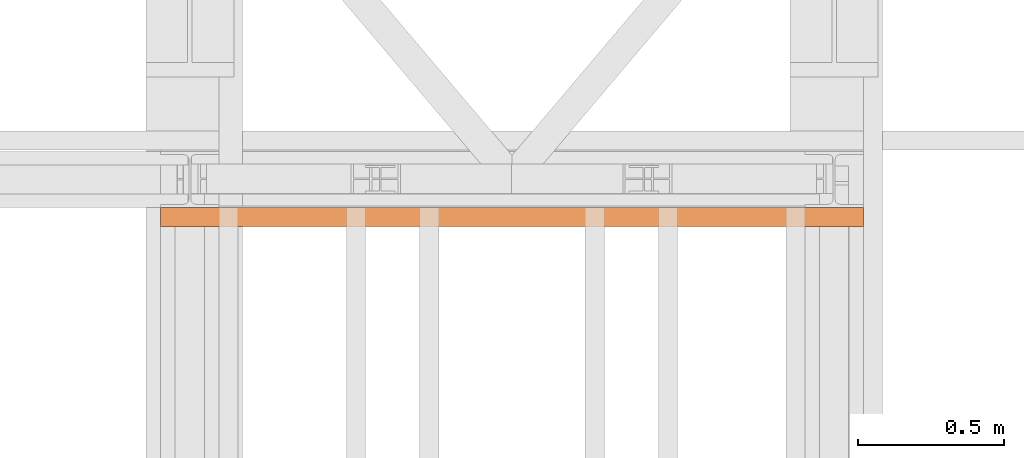
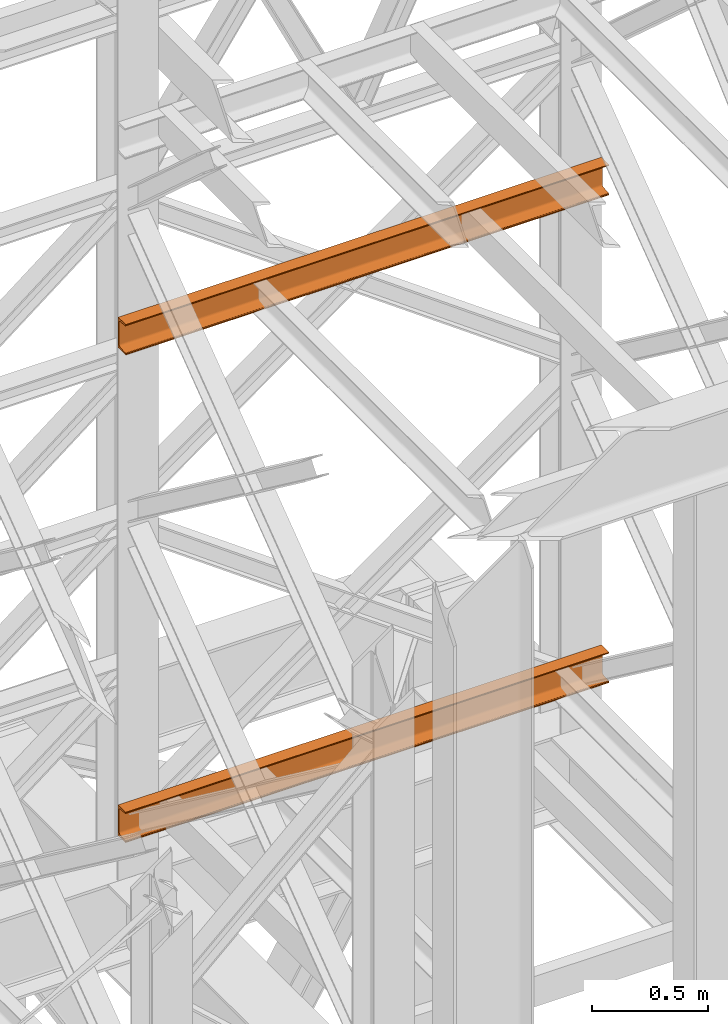
# One storey, part 189 of 208: 2 proxies.
"""IFC2X3 building model written with IfcOpenShell, lengths in millimetres."""

from ifc_helpers import new_model, entity, si_unit, converted_unit, frame, origin, origin_with_axes, place, context, subcontext, project, spatial, faceted_brep, element, save


model = new_model("IFC2X3")

# Units and contexts
model_context = context("Model", 3, precision=1e-05, world=origin())
plan_context = context("Plan", 3, precision=1e-05, world=origin())
body_context = subcontext(model_context, "Body", "Model", "MODEL_VIEW")
ifc_project = project(units=[si_unit("LENGTHUNIT", "METRE", prefix="MILLI"), converted_unit("PLANEANGLEUNIT", "DEGREE", entity("IfcPlaneAngleMeasure", 0.0174532925199433), si_unit("PLANEANGLEUNIT", "RADIAN"), dimensions=[0, 0, 0, 0, 0, 0, 0]), si_unit("AREAUNIT", "SQUARE_METRE"), si_unit("VOLUMEUNIT", "CUBIC_METRE")], contexts=[model_context, plan_context])

# Building, storey
building_placement = place(None, origin())
building = spatial("IfcBuilding", under=ifc_project, at=building_placement, CompositionType="COMPLEX")
storey_placement = place(building_placement, origin_with_axes())
storey = spatial("IfcBuildingStorey", under=building, at=storey_placement, Name="Geschoss", CompositionType="ELEMENT")

# Proxies
proxy_1_placement = place(storey_placement, frame((6493.301735402971, -13922.58293018712, 5524.960005364417), z_axis=(0.0, 0.0, 1.0), x_axis=(1.0, 0.0, 0.0)))
element("IfcBuildingElementProxy", 1, at=proxy_1_placement, inside=storey, context=body_context, shape_type="Brep", body=[
    faceted_brep([(2399.962597713924, 65.01000000000022, 160.0100000000002), (2399.962597713924, 0.01000000000021828, 160.0100000000002), (0.01000000000021828, 0.01853275732901238, 160.0100000000002), (0.01000000000021828, 65.01853275732901, 160.0100000000002), (2399.962597713924, 0.01000000000021828, 160.0100000000002), (2399.962597713924, 0.01000000000021828, 156.8875719297539), (0.01000000000021828, 0.01853275732901238, 156.8875719297539), (0.01000000000021828, 0.01853275732901238, 160.0100000000002), (2399.962597713924, 0.01000000000021828, 156.8875719297539), (2399.962597713924, 0.2527365771729819, 155.2717110918293), (0.01000000000021828, 0.261269334501776, 155.2717110918293), (0.01000000000021828, 0.01853275732901238, 156.8875719297539), (2399.962597713924, 0.2527365771729819, 155.2717110918293), (2399.962597713924, 0.959467714144921, 153.7984655565542), (0.01000000000021828, 0.9680004714700772, 153.7984655565542), (0.01000000000021828, 0.261269334501776, 155.2717110918293), (2399.962597713924, 0.959467714144921, 153.7984655565542), (2399.962597713924, 2.067848361532015, 152.5978732961266), (0.01000000000021828, 2.076381118860809, 152.5978732961266), (0.01000000000021828, 0.9680004714700772, 153.7984655565542), (2399.962597713924, 2.067848361532015, 152.5978732961266), (2399.962597713924, 3.480043588517219, 151.7759086082897), (0.01000000000021828, 3.488576345846013, 151.7759086082897), (0.01000000000021828, 2.076381118860809, 152.5978732961266), (2399.962597713924, 3.480043588517219, 151.7759086082897), (2399.962597713924, 5.071401277446057, 151.4050878978051), (0.01000000000021828, 5.079934034774851, 151.4050878978051), (0.01000000000021828, 3.488576345846013, 151.7759086082897), (2399.962597713924, 5.071401277446057, 151.4050878978051), (2399.962597713924, 47.84732483397056, 147.9830140132835), (0.01000000000021828, 47.85585759129936, 147.9830140132835), (0.01000000000021828, 5.079934034774851, 151.4050878978051), (2399.962597713924, 47.84732483397056, 147.9830140132835), (2399.962597713924, 50.8115917919913, 147.318026761528), (0.01000000000021828, 50.8201245493201, 147.318026761528), (0.01000000000021828, 47.85585759129936, 147.9830140132835), (2399.962597713924, 50.8115917919913, 147.318026761528), (2399.962597713924, 53.5813804007139, 145.7058782528511), (0.01000000000021828, 53.58991315803905, 145.7058782528511), (0.01000000000021828, 50.8201245493201, 147.318026761528), (2399.962597713924, 53.5813804007139, 145.7058782528511), (2399.962597713924, 55.69737981845356, 143.4138384829421), (0.01000000000021828, 55.70591257578235, 143.4138384829421), (0.01000000000021828, 53.58991315803905, 145.7058782528511), (2399.962597713924, 55.69737981845356, 143.4138384829421), (2399.962597713924, 57.04659380721387, 140.6012788246917), (0.01000000000021828, 57.05512656454266, 140.6012788246917), (0.01000000000021828, 55.70591257578235, 143.4138384829421), (2399.962597713924, 57.04659380721387, 140.6012788246917), (2399.962597713924, 57.51000000000022, 137.5164535886543), (0.01000000000021828, 57.51853275732901, 137.5164535886543), (0.01000000000021828, 57.05512656454266, 140.6012788246917), (2399.962597713924, 57.51000000000022, 137.5164535886543), (2399.962597713924, 57.51000000000022, 22.503546411348), (0.01000000000021828, 57.51853275732901, 22.503546411348), (0.01000000000021828, 57.51853275732901, 137.5164535886543), (2399.962597713924, 57.51000000000022, 22.503546411348), (2399.962597713924, 57.04659380721387, 19.41872117530875), (0.01000000000021828, 57.05512656454266, 19.41872117530875), (0.01000000000021828, 57.51853275732901, 22.503546411348), (2399.962597713924, 57.04659380721387, 19.41872117530875), (2399.962597713924, 55.69737981845356, 16.60616151705835), (0.01000000000021828, 55.70591257578235, 16.60616151705835), (0.01000000000021828, 57.05512656454266, 19.41872117530875), (2399.962597713924, 55.69737981845356, 16.60616151705835), (2399.962597713924, 53.5813804007139, 14.31412174714933), (0.01000000000021828, 53.58991315803905, 14.31412174714933), (0.01000000000021828, 55.70591257578235, 16.60616151705835), (2399.962597713924, 53.5813804007139, 14.31412174714933), (2399.962597713924, 50.88537133101818, 12.74491643400688), (0.01000000000021828, 50.89390408834333, 12.74491643400688), (0.01000000000021828, 53.58991315803905, 14.31412174714933), (2399.962597713924, 50.88537133101818, 12.74491643400688), (2399.962597713924, 47.84732483397056, 12.03698598671872), (0.01000000000021828, 47.85585759129936, 12.03698598671872), (0.01000000000021828, 50.89390408834333, 12.74491643400688), (2399.962597713924, 47.84732483397056, 12.03698598671872), (2399.962597713924, 5.071401277446057, 8.614912102195376), (0.01000000000021828, 5.079934034774851, 8.614912102195376), (0.01000000000021828, 47.85585759129936, 12.03698598671872), (2399.962597713924, 5.071401277446057, 8.614912102195376), (2399.962597713924, 3.480043588517219, 8.244091391710754), (0.01000000000021828, 3.488576345846013, 8.244091391710754), (0.01000000000021828, 5.079934034774851, 8.614912102195376), (2399.962597713924, 3.480043588517219, 8.244091391710754), (2399.962597713924, 2.067848361532015, 7.422126703873801), (0.01000000000021828, 2.076381118860809, 7.422126703873801), (0.01000000000021828, 3.488576345846013, 8.244091391710754), (2399.962597713924, 2.067848361532015, 7.422126703873801), (2399.962597713924, 0.959467714144921, 6.221534443446217), (0.01000000000021828, 0.9680004714700772, 6.221534443446217), (0.01000000000021828, 2.076381118860809, 7.422126703873801), (2399.962597713924, 0.959467714144921, 6.221534443446217), (2399.962597713924, 0.2527365771729819, 4.748288908172981), (0.01000000000021828, 0.261269334501776, 4.748288908172981), (0.01000000000021828, 0.9680004714700772, 6.221534443446217), (2399.962597713924, 0.2527365771729819, 4.748288908172981), (2399.962597713924, 0.01000000000021828, 0.01000000000021828), (0.01000000000021828, 0.01853275732901238, 0.01000000000021828), (0.01000000000021828, 0.261269334501776, 4.748288908172981), (2399.962597713924, 0.01000000000021828, 0.01000000000021828), (2399.962597713924, 65.01000000000022, 0.01000000000021828), (0.01000000000021828, 65.01853275732901, 0.01000000000021828), (0.01000000000021828, 0.01853275732901238, 0.01000000000021828), (2399.962597713924, 65.01000000000022, 0.01000000000021828), (2399.962597713924, 65.01000000000022, 160.0100000000002), (0.01000000000021828, 65.01853275732901, 160.0100000000002), (0.01000000000021828, 65.01853275732901, 0.01000000000021828), (2399.962597713924, 65.01000000000022, 160.0100000000002), (2399.962597713924, 65.01000000000022, 0.01000000000021828), (2399.962597713924, 0.01000000000021828, 0.01000000000021828), (2399.962597713924, 0.2527365771729819, 4.748288908172981), (2399.962597713924, 0.959467714144921, 6.221534443446217), (2399.962597713924, 2.067848361532015, 7.422126703873801), (2399.962597713924, 3.480043588517219, 8.244091391710754), (2399.962597713924, 5.071401277446057, 8.614912102195376), (2399.962597713924, 47.84732483397056, 12.03698598671872), (2399.962597713924, 50.88537133101818, 12.74491643400688), (2399.962597713924, 53.5813804007139, 14.31412174714933), (2399.962597713924, 55.69737981845356, 16.60616151705835), (2399.962597713924, 57.04659380721387, 19.41872117530875), (2399.962597713924, 57.51000000000022, 22.503546411348), (2399.962597713924, 57.51000000000022, 137.5164535886543), (2399.962597713924, 57.04659380721387, 140.6012788246917), (2399.962597713924, 55.69737981845356, 143.4138384829421), (2399.962597713924, 53.5813804007139, 145.7058782528511), (2399.962597713924, 50.8115917919913, 147.318026761528), (2399.962597713924, 47.84732483397056, 147.9830140132835), (2399.962597713924, 5.071401277446057, 151.4050878978051), (2399.962597713924, 3.480043588517219, 151.7759086082897), (2399.962597713924, 2.067848361532015, 152.5978732961266), (2399.962597713924, 0.959467714144921, 153.7984655565542), (2399.962597713924, 0.2527365771729819, 155.2717110918293), (2399.962597713924, 0.01000000000021828, 156.8875719297539), (2399.962597713924, 0.01000000000021828, 160.0100000000002), (0.01000000000021828, 65.01853275732901, 160.0100000000002), (0.01000000000021828, 0.01853275732901238, 160.0100000000002), (0.01000000000021828, 0.01853275732901238, 156.8875719297539), (0.01000000000021828, 0.261269334501776, 155.2717110918293), (0.01000000000021828, 0.9680004714700772, 153.7984655565542), (0.01000000000021828, 2.076381118860809, 152.5978732961266), (0.01000000000021828, 3.488576345846013, 151.7759086082897), (0.01000000000021828, 5.079934034774851, 151.4050878978051), (0.01000000000021828, 47.85585759129936, 147.9830140132835), (0.01000000000021828, 50.8201245493201, 147.318026761528), (0.01000000000021828, 53.58991315803905, 145.7058782528511), (0.01000000000021828, 55.70591257578235, 143.4138384829421), (0.01000000000021828, 57.05512656454266, 140.6012788246917), (0.01000000000021828, 57.51853275732901, 137.5164535886543), (0.01000000000021828, 57.51853275732901, 22.503546411348), (0.01000000000021828, 57.05512656454266, 19.41872117530875), (0.01000000000021828, 55.70591257578235, 16.60616151705835), (0.01000000000021828, 53.58991315803905, 14.31412174714933), (0.01000000000021828, 50.89390408834333, 12.74491643400688), (0.01000000000021828, 47.85585759129936, 12.03698598671872), (0.01000000000021828, 5.079934034774851, 8.614912102195376), (0.01000000000021828, 3.488576345846013, 8.244091391710754), (0.01000000000021828, 2.076381118860809, 7.422126703873801), (0.01000000000021828, 0.9680004714700772, 6.221534443446217), (0.01000000000021828, 0.261269334501776, 4.748288908172981), (0.01000000000021828, 0.01853275732901238, 0.01000000000021828), (0.01000000000021828, 65.01853275732901, 0.01000000000021828)], [[[0, 1, 2, 3]], [[4, 5, 6, 7]], [[8, 9, 10, 11]], [[12, 13, 14, 15]], [[16, 17, 18, 19]], [[20, 21, 22, 23]], [[24, 25, 26, 27]], [[28, 29, 30, 31]], [[32, 33, 34, 35]], [[36, 37, 38, 39]], [[40, 41, 42, 43]], [[44, 45, 46, 47]], [[48, 49, 50, 51]], [[52, 53, 54, 55]], [[56, 57, 58, 59]], [[60, 61, 62, 63]], [[64, 65, 66, 67]], [[68, 69, 70, 71]], [[72, 73, 74, 75]], [[76, 77, 78, 79]], [[80, 81, 82, 83]], [[84, 85, 86, 87]], [[88, 89, 90, 91]], [[92, 93, 94, 95]], [[96, 97, 98, 99]], [[100, 101, 102, 103]], [[104, 105, 106, 107]], [[108, 109, 110, 111, 112, 113, 114, 115, 116, 117, 118, 119, 120, 121, 122, 123, 124, 125, 126, 127, 128, 129, 130, 131, 132, 133, 134]], [[135, 136, 137, 138, 139, 140, 141, 142, 143, 144, 145, 146, 147, 148, 149, 150, 151, 152, 153, 154, 155, 156, 157, 158, 159, 160, 161]]], orient=[[False], [False], [False], [False], [False], [False], [False], [False], [False], [False], [False], [False], [False], [False], [False], [False], [False], [False], [False], [False], [False], [False], [False], [False], [False], [False], [False], [False], [False]]),
])
proxy_2_placement = place(storey_placement, frame((6493.301735402971, -13922.58293018712, 8084.960005364417), z_axis=(0.0, 0.0, 1.0), x_axis=(1.0, 0.0, 0.0)))
element("IfcBuildingElementProxy", 2, at=proxy_2_placement, inside=storey, context=body_context, shape_type="Brep", body=[
    faceted_brep([(2399.962597713924, 65.01000000000022, 160.0100000000002), (2399.962597713924, 0.01000000000021828, 160.0100000000002), (0.01000000000021828, 0.01853275732901238, 160.0100000000002), (0.01000000000021828, 65.01853275732901, 160.0100000000002), (2399.962597713924, 0.01000000000021828, 160.0100000000002), (2399.962597713924, 0.01000000000021828, 156.8875719297539), (0.01000000000021828, 0.01853275732901238, 156.8875719297539), (0.01000000000021828, 0.01853275732901238, 160.0100000000002), (2399.962597713924, 0.01000000000021828, 156.8875719297539), (2399.962597713924, 0.2527365771729819, 155.2717110918293), (0.01000000000021828, 0.261269334501776, 155.2717110918293), (0.01000000000021828, 0.01853275732901238, 156.8875719297539), (2399.962597713924, 0.2527365771729819, 155.2717110918293), (2399.962597713924, 0.959467714144921, 153.7984655565542), (0.01000000000021828, 0.9680004714700772, 153.7984655565542), (0.01000000000021828, 0.261269334501776, 155.2717110918293), (2399.962597713924, 0.959467714144921, 153.7984655565542), (2399.962597713924, 2.067848361532015, 152.5978732961266), (0.01000000000021828, 2.076381118860809, 152.5978732961266), (0.01000000000021828, 0.9680004714700772, 153.7984655565542), (2399.962597713924, 2.067848361532015, 152.5978732961266), (2399.962597713924, 3.480043588517219, 151.7759086082897), (0.01000000000021828, 3.488576345846013, 151.7759086082897), (0.01000000000021828, 2.076381118860809, 152.5978732961266), (2399.962597713924, 3.480043588517219, 151.7759086082897), (2399.962597713924, 5.071401277446057, 151.4050878978051), (0.01000000000021828, 5.079934034774851, 151.4050878978051), (0.01000000000021828, 3.488576345846013, 151.7759086082897), (2399.962597713924, 5.071401277446057, 151.4050878978051), (2399.962597713924, 47.84732483397056, 147.9830140132835), (0.01000000000021828, 47.85585759129936, 147.9830140132835), (0.01000000000021828, 5.079934034774851, 151.4050878978051), (2399.962597713924, 47.84732483397056, 147.9830140132835), (2399.962597713924, 50.8115917919913, 147.318026761528), (0.01000000000021828, 50.8201245493201, 147.318026761528), (0.01000000000021828, 47.85585759129936, 147.9830140132835), (2399.962597713924, 50.8115917919913, 147.318026761528), (2399.962597713924, 53.5813804007139, 145.7058782528511), (0.01000000000021828, 53.58991315803905, 145.7058782528511), (0.01000000000021828, 50.8201245493201, 147.318026761528), (2399.962597713924, 53.5813804007139, 145.7058782528511), (2399.962597713924, 55.69737981845356, 143.4138384829421), (0.01000000000021828, 55.70591257578235, 143.4138384829421), (0.01000000000021828, 53.58991315803905, 145.7058782528511), (2399.962597713924, 55.69737981845356, 143.4138384829421), (2399.962597713924, 57.04659380721387, 140.6012788246917), (0.01000000000021828, 57.05512656454266, 140.6012788246917), (0.01000000000021828, 55.70591257578235, 143.4138384829421), (2399.962597713924, 57.04659380721387, 140.6012788246917), (2399.962597713924, 57.51000000000022, 137.5164535886543), (0.01000000000021828, 57.51853275732901, 137.5164535886543), (0.01000000000021828, 57.05512656454266, 140.6012788246917), (2399.962597713924, 57.51000000000022, 137.5164535886543), (2399.962597713924, 57.51000000000022, 22.503546411348), (0.01000000000021828, 57.51853275732901, 22.503546411348), (0.01000000000021828, 57.51853275732901, 137.5164535886543), (2399.962597713924, 57.51000000000022, 22.503546411348), (2399.962597713924, 57.04659380721387, 19.41872117530875), (0.01000000000021828, 57.05512656454266, 19.41872117530875), (0.01000000000021828, 57.51853275732901, 22.503546411348), (2399.962597713924, 57.04659380721387, 19.41872117530875), (2399.962597713924, 55.69737981845356, 16.60616151705835), (0.01000000000021828, 55.70591257578235, 16.60616151705835), (0.01000000000021828, 57.05512656454266, 19.41872117530875), (2399.962597713924, 55.69737981845356, 16.60616151705835), (2399.962597713924, 53.5813804007139, 14.31412174714933), (0.01000000000021828, 53.58991315803905, 14.31412174714933), (0.01000000000021828, 55.70591257578235, 16.60616151705835), (2399.962597713924, 53.5813804007139, 14.31412174714933), (2399.962597713924, 50.88537133101818, 12.74491643400688), (0.01000000000021828, 50.89390408834333, 12.74491643400688), (0.01000000000021828, 53.58991315803905, 14.31412174714933), (2399.962597713924, 50.88537133101818, 12.74491643400688), (2399.962597713924, 47.84732483397056, 12.03698598671872), (0.01000000000021828, 47.85585759129936, 12.03698598671872), (0.01000000000021828, 50.89390408834333, 12.74491643400688), (2399.962597713924, 47.84732483397056, 12.03698598671872), (2399.962597713924, 5.071401277446057, 8.614912102195376), (0.01000000000021828, 5.079934034774851, 8.614912102195376), (0.01000000000021828, 47.85585759129936, 12.03698598671872), (2399.962597713924, 5.071401277446057, 8.614912102195376), (2399.962597713924, 3.480043588517219, 8.244091391710754), (0.01000000000021828, 3.488576345846013, 8.244091391710754), (0.01000000000021828, 5.079934034774851, 8.614912102195376), (2399.962597713924, 3.480043588517219, 8.244091391710754), (2399.962597713924, 2.067848361532015, 7.422126703873801), (0.01000000000021828, 2.076381118860809, 7.422126703873801), (0.01000000000021828, 3.488576345846013, 8.244091391710754), (2399.962597713924, 2.067848361532015, 7.422126703873801), (2399.962597713924, 0.959467714144921, 6.221534443446217), (0.01000000000021828, 0.9680004714700772, 6.221534443446217), (0.01000000000021828, 2.076381118860809, 7.422126703873801), (2399.962597713924, 0.959467714144921, 6.221534443446217), (2399.962597713924, 0.2527365771729819, 4.748288908172981), (0.01000000000021828, 0.261269334501776, 4.748288908172981), (0.01000000000021828, 0.9680004714700772, 6.221534443446217), (2399.962597713924, 0.2527365771729819, 4.748288908172981), (2399.962597713924, 0.01000000000021828, 0.01000000000021828), (0.01000000000021828, 0.01853275732901238, 0.01000000000021828), (0.01000000000021828, 0.261269334501776, 4.748288908172981), (2399.962597713924, 0.01000000000021828, 0.01000000000021828), (2399.962597713924, 65.01000000000022, 0.01000000000021828), (0.01000000000021828, 65.01853275732901, 0.01000000000021828), (0.01000000000021828, 0.01853275732901238, 0.01000000000021828), (2399.962597713924, 65.01000000000022, 0.01000000000021828), (2399.962597713924, 65.01000000000022, 160.0100000000002), (0.01000000000021828, 65.01853275732901, 160.0100000000002), (0.01000000000021828, 65.01853275732901, 0.01000000000021828), (2399.962597713924, 65.01000000000022, 160.0100000000002), (2399.962597713924, 65.01000000000022, 0.01000000000021828), (2399.962597713924, 0.01000000000021828, 0.01000000000021828), (2399.962597713924, 0.2527365771729819, 4.748288908172981), (2399.962597713924, 0.959467714144921, 6.221534443446217), (2399.962597713924, 2.067848361532015, 7.422126703873801), (2399.962597713924, 3.480043588517219, 8.244091391710754), (2399.962597713924, 5.071401277446057, 8.614912102195376), (2399.962597713924, 47.84732483397056, 12.03698598671872), (2399.962597713924, 50.88537133101818, 12.74491643400688), (2399.962597713924, 53.5813804007139, 14.31412174714933), (2399.962597713924, 55.69737981845356, 16.60616151705835), (2399.962597713924, 57.04659380721387, 19.41872117530875), (2399.962597713924, 57.51000000000022, 22.503546411348), (2399.962597713924, 57.51000000000022, 137.5164535886543), (2399.962597713924, 57.04659380721387, 140.6012788246917), (2399.962597713924, 55.69737981845356, 143.4138384829421), (2399.962597713924, 53.5813804007139, 145.7058782528511), (2399.962597713924, 50.8115917919913, 147.318026761528), (2399.962597713924, 47.84732483397056, 147.9830140132835), (2399.962597713924, 5.071401277446057, 151.4050878978051), (2399.962597713924, 3.480043588517219, 151.7759086082897), (2399.962597713924, 2.067848361532015, 152.5978732961266), (2399.962597713924, 0.959467714144921, 153.7984655565542), (2399.962597713924, 0.2527365771729819, 155.2717110918293), (2399.962597713924, 0.01000000000021828, 156.8875719297539), (2399.962597713924, 0.01000000000021828, 160.0100000000002), (0.01000000000021828, 65.01853275732901, 160.0100000000002), (0.01000000000021828, 0.01853275732901238, 160.0100000000002), (0.01000000000021828, 0.01853275732901238, 156.8875719297539), (0.01000000000021828, 0.261269334501776, 155.2717110918293), (0.01000000000021828, 0.9680004714700772, 153.7984655565542), (0.01000000000021828, 2.076381118860809, 152.5978732961266), (0.01000000000021828, 3.488576345846013, 151.7759086082897), (0.01000000000021828, 5.079934034774851, 151.4050878978051), (0.01000000000021828, 47.85585759129936, 147.9830140132835), (0.01000000000021828, 50.8201245493201, 147.318026761528), (0.01000000000021828, 53.58991315803905, 145.7058782528511), (0.01000000000021828, 55.70591257578235, 143.4138384829421), (0.01000000000021828, 57.05512656454266, 140.6012788246917), (0.01000000000021828, 57.51853275732901, 137.5164535886543), (0.01000000000021828, 57.51853275732901, 22.503546411348), (0.01000000000021828, 57.05512656454266, 19.41872117530875), (0.01000000000021828, 55.70591257578235, 16.60616151705835), (0.01000000000021828, 53.58991315803905, 14.31412174714933), (0.01000000000021828, 50.89390408834333, 12.74491643400688), (0.01000000000021828, 47.85585759129936, 12.03698598671872), (0.01000000000021828, 5.079934034774851, 8.614912102195376), (0.01000000000021828, 3.488576345846013, 8.244091391710754), (0.01000000000021828, 2.076381118860809, 7.422126703873801), (0.01000000000021828, 0.9680004714700772, 6.221534443446217), (0.01000000000021828, 0.261269334501776, 4.748288908172981), (0.01000000000021828, 0.01853275732901238, 0.01000000000021828), (0.01000000000021828, 65.01853275732901, 0.01000000000021828)], [[[0, 1, 2, 3]], [[4, 5, 6, 7]], [[8, 9, 10, 11]], [[12, 13, 14, 15]], [[16, 17, 18, 19]], [[20, 21, 22, 23]], [[24, 25, 26, 27]], [[28, 29, 30, 31]], [[32, 33, 34, 35]], [[36, 37, 38, 39]], [[40, 41, 42, 43]], [[44, 45, 46, 47]], [[48, 49, 50, 51]], [[52, 53, 54, 55]], [[56, 57, 58, 59]], [[60, 61, 62, 63]], [[64, 65, 66, 67]], [[68, 69, 70, 71]], [[72, 73, 74, 75]], [[76, 77, 78, 79]], [[80, 81, 82, 83]], [[84, 85, 86, 87]], [[88, 89, 90, 91]], [[92, 93, 94, 95]], [[96, 97, 98, 99]], [[100, 101, 102, 103]], [[104, 105, 106, 107]], [[108, 109, 110, 111, 112, 113, 114, 115, 116, 117, 118, 119, 120, 121, 122, 123, 124, 125, 126, 127, 128, 129, 130, 131, 132, 133, 134]], [[135, 136, 137, 138, 139, 140, 141, 142, 143, 144, 145, 146, 147, 148, 149, 150, 151, 152, 153, 154, 155, 156, 157, 158, 159, 160, 161]]], orient=[[False], [False], [False], [False], [False], [False], [False], [False], [False], [False], [False], [False], [False], [False], [False], [False], [False], [False], [False], [False], [False], [False], [False], [False], [False], [False], [False], [False], [False]]),
])

save(model, "model.ifc")
